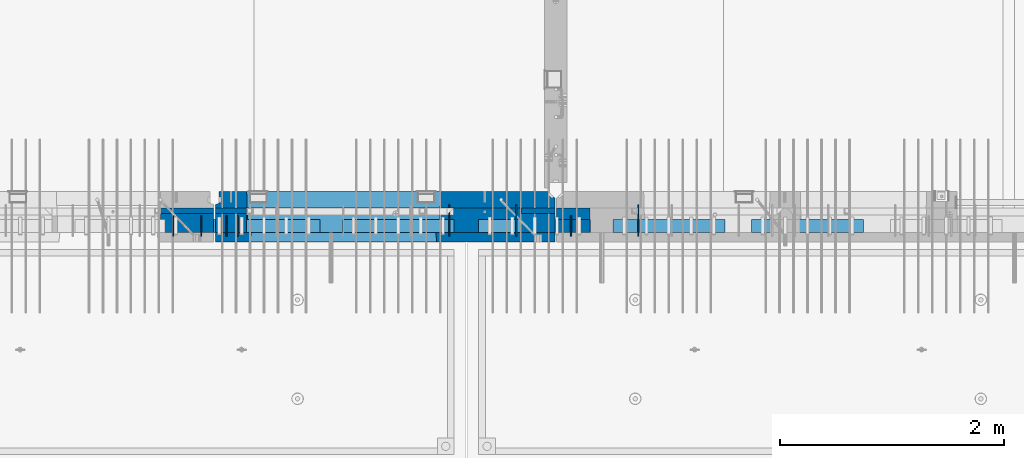
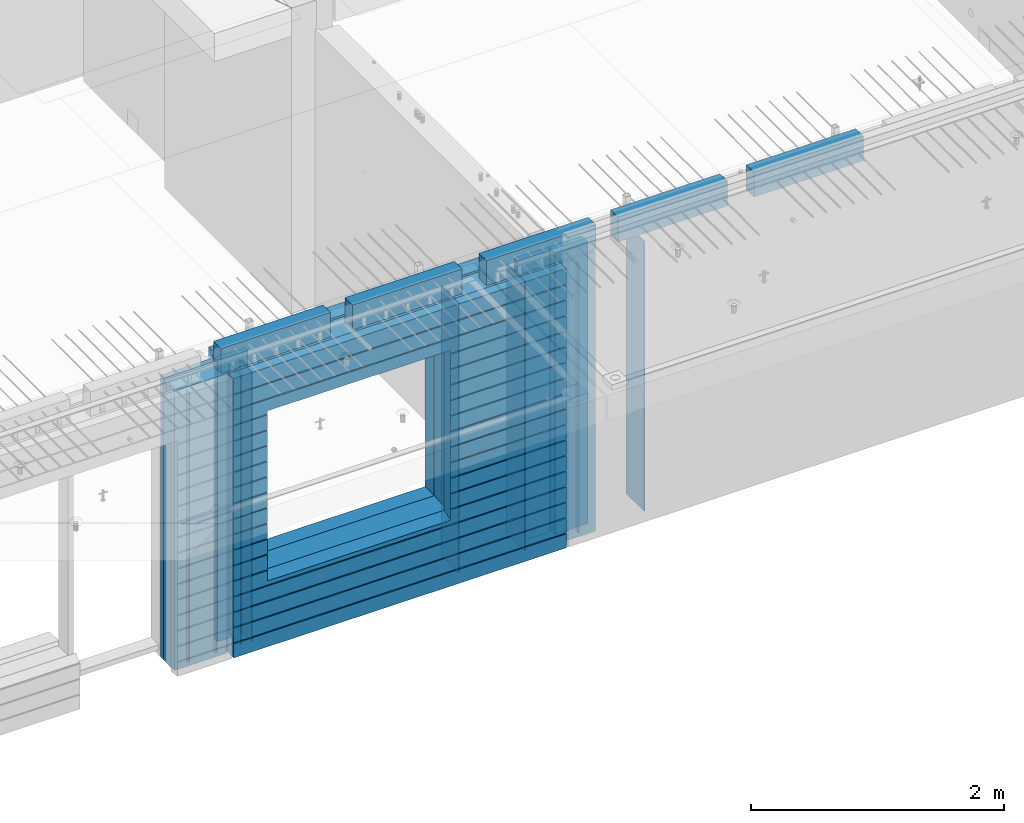
# One storey, part 224 of 341: 24 walls, 10 elements without a shape of their own.
"""IFC2X3 building model written with IfcOpenShell, lengths in millimetres."""

from ifc_helpers import new_model, si_unit, frame, origin_with_axes, place, context, subcontext, project, spatial, faceted_brep, material, type_object, element, aggregate, save


model = new_model("IFC2X3")

# Units and contexts
model_context = context("Model", 3, precision=1e-05, world=origin_with_axes())
body_context = subcontext(model_context, "Body", "Model", "MODEL_VIEW")
ifc_project = project(units=[si_unit("LENGTHUNIT", "METRE", prefix="MILLI"), si_unit("AREAUNIT", "SQUARE_METRE"), si_unit("VOLUMEUNIT", "CUBIC_METRE"), si_unit("MASSUNIT", "GRAM", prefix="KILO"), si_unit("TIMEUNIT", "SECOND"), si_unit("PLANEANGLEUNIT", "RADIAN"), si_unit("SOLIDANGLEUNIT", "STERADIAN"), si_unit("THERMODYNAMICTEMPERATUREUNIT", "DEGREE_CELSIUS"), si_unit("LUMINOUSINTENSITYUNIT", "LUMEN")], contexts=[model_context])

# Site, building, storey
site_placement = place(None, origin_with_axes())
site = spatial("IfcSite", under=ifc_project, at=site_placement, CompositionType="ELEMENT")
building_placement = place(site_placement, origin_with_axes())
building = spatial("IfcBuilding", under=site, at=building_placement, CompositionType="ELEMENT")
storey_placement = place(building_placement, origin_with_axes())
storey = spatial("IfcBuildingStorey", under=building, at=storey_placement, Name="5", CompositionType="ELEMENT", Elevation=0.0)

# Assembly, walls
assembly_1_placement = place(storey_placement, origin_with_axes())
assembly_1 = element("IfcElementAssembly", 1, at=assembly_1_placement, inside=storey, AssemblyPlace="NOTDEFINED", PredefinedType="REINFORCEMENT_UNIT")
ifc_material_1 = material(Name="Undefined")
wall_type_1 = type_object("IfcWallType", PredefinedType="NOTDEFINED")
wall_1_placement = place(assembly_1_placement, frame((25665.0, 7780.0, 95115.0), z_axis=(0.0, 0.0, 1.0), x_axis=(0.0, -1.0, 0.0)))
wall_1 = element("IfcWall", 2, at=wall_1_placement, type_object=wall_type_1, material=ifc_material_1, Name="(PD)", context=body_context, shape_type="Brep", body=[
    faceted_brep([(0.0, 5.0, -1300.0), (0.0, 5.0, 1300.0), (180.0, 5.0, 1300.0), (180.0, 5.0, -1300.0), (0.0, -5.0, 1300.0), (180.0, -5.0, 1300.0), (0.0, -5.0, -1300.0), (180.0, -5.0, -1300.0)], [[[0, 1, 2, 3]], [[1, 4, 5, 2]], [[4, 6, 7, 5]], [[6, 0, 3, 7]], [[5, 7, 3, 2]], [[6, 4, 1, 0]]]),
])
wall_2_placement = place(assembly_1_placement, frame((25765.0, 7780.0, 95115.0), z_axis=(0.0, 0.0, 1.0), x_axis=(0.0, -1.0, 0.0)))
wall_2 = element("IfcWall", 3, at=wall_2_placement, type_object=wall_type_1, material=ifc_material_1, Name="(PD)", context=body_context, shape_type="Brep", body=[
    faceted_brep([(0.0, 5.0, -1300.0), (0.0, 5.0, 1300.0), (180.0, 5.0, 1300.0), (180.0, 5.0, -1300.0), (0.0, -5.0, 1300.0), (180.0, -5.0, 1300.0), (0.0, -5.0, -1300.0), (180.0, -5.0, -1300.0)], [[[0, 1, 2, 3]], [[1, 4, 5, 2]], [[4, 6, 7, 5]], [[6, 0, 3, 7]], [[5, 7, 3, 2]], [[6, 4, 1, 0]]]),
])
wall_3_placement = place(assembly_1_placement, frame((28255.0, 7880.0, 95115.0), z_axis=(0.0, 0.0, 1.0), x_axis=(0.0, -1.0, 0.0)))
wall_3 = element("IfcWall", 4, at=wall_3_placement, type_object=wall_type_1, material=ifc_material_1, Name="(PD)", context=body_context, shape_type="Brep", body=[
    faceted_brep([(0.0, 5.0, -1300.0), (0.0, 5.0, 1300.0), (280.0, 5.0, 1300.0), (280.0, 5.0, -1300.0), (0.0, -5.0, 1300.0), (280.0, -5.0, 1300.0), (0.0, -5.0, -1300.0), (280.0, -5.0, -1300.0)], [[[0, 1, 2, 3]], [[1, 4, 5, 2]], [[4, 6, 7, 5]], [[6, 0, 3, 7]], [[5, 7, 3, 2]], [[6, 4, 1, 0]]]),
])

assembly_2_placement = place(storey_placement, origin_with_axes())
assembly_2 = element("IfcElementAssembly", 5, at=assembly_2_placement, inside=storey, AssemblyPlace="NOTDEFINED", PredefinedType="REINFORCEMENT_UNIT")
wall_4_placement = place(assembly_2_placement, frame((28745.0021834468, 7780.0, 95115.0), z_axis=(0.0, 0.0, 1.0), x_axis=(0.0, -1.0, 0.0)))
wall_4 = element("IfcWall", 6, at=wall_4_placement, type_object=wall_type_1, material=ifc_material_1, Name="(PD)", context=body_context, shape_type="Brep", body=[
    faceted_brep([(0.0, 5.0, -1300.0), (0.0, 5.0, 1300.0), (180.0, 5.0, 1300.0), (180.0, 5.0, -1300.0), (0.0, -5.0, 1300.0), (180.0, -5.0, 1300.0), (0.0, -5.0, -1300.0), (180.0, -5.0, -1300.0)], [[[0, 1, 2, 3]], [[1, 4, 5, 2]], [[4, 6, 7, 5]], [[6, 0, 3, 7]], [[5, 7, 3, 2]], [[6, 4, 1, 0]]]),
])
wall_5_placement = place(assembly_2_placement, frame((29345.0021834468, 7880.0, 95115.0), z_axis=(0.0, 0.0, 1.0), x_axis=(0.0, -1.0, 0.0)))
wall_5 = element("IfcWall", 7, at=wall_5_placement, type_object=wall_type_1, material=ifc_material_1, Name="(PD)", context=body_context, shape_type="Brep", body=[
    faceted_brep([(0.0, 5.0, -1300.0), (0.0, 5.0, 1300.0), (280.0, 5.0, 1300.0), (280.0, 5.0, -1300.0), (0.0, -5.0, 1300.0), (280.0, -5.0, 1300.0), (0.0, -5.0, -1300.0), (280.0, -5.0, -1300.0)], [[[0, 1, 2, 3]], [[1, 4, 5, 2]], [[4, 6, 7, 5]], [[6, 0, 3, 7]], [[5, 7, 3, 2]], [[6, 4, 1, 0]]]),
])

assembly_3_placement = place(storey_placement, origin_with_axes())
assembly_3 = element("IfcElementAssembly", 8, at=assembly_3_placement, inside=storey, AssemblyPlace="NOTDEFINED", PredefinedType="REINFORCEMENT_UNIT")
wall_6_placement = place(assembly_3_placement, frame((25190.0, 7780.0, 95115.0), z_axis=(0.0, 0.0, 1.0), x_axis=(0.0, -1.0, 0.0)))
wall_6 = element("IfcWall", 9, at=wall_6_placement, type_object=wall_type_1, material=ifc_material_1, Name="(PD)", context=body_context, shape_type="Brep", body=[
    faceted_brep([(0.0, 5.0, -1300.0), (0.0, 5.0, 1300.0), (180.0, 5.0, 1300.0), (180.0, 5.0, -1300.0), (0.0, -5.0, 1300.0), (180.0, -5.0, 1300.0), (0.0, -5.0, -1300.0), (180.0, -5.0, -1300.0)], [[[0, 1, 2, 3]], [[1, 4, 5, 2]], [[4, 6, 7, 5]], [[6, 0, 3, 7]], [[5, 7, 3, 2]], [[6, 4, 1, 0]]]),
])
wall_7_placement = place(assembly_3_placement, frame((25440.0, 7780.0, 95115.0), z_axis=(0.0, 0.0, 1.0), x_axis=(0.0, -1.0, 0.0)))
wall_7 = element("IfcWall", 10, at=wall_7_placement, type_object=wall_type_1, material=ifc_material_1, Name="(PD)", context=body_context, shape_type="Brep", body=[
    faceted_brep([(0.0, 5.0, -1300.0), (0.0, 5.0, 1300.0), (180.0, 5.0, 1300.0), (180.0, 5.0, -1300.0), (0.0, -5.0, 1300.0), (180.0, -5.0, 1300.0), (0.0, -5.0, -1300.0), (180.0, -5.0, -1300.0)], [[[0, 1, 2, 3]], [[1, 4, 5, 2]], [[4, 6, 7, 5]], [[6, 0, 3, 7]], [[5, 7, 3, 2]], [[6, 4, 1, 0]]]),
])

# Wall
wall_8_placement = place(assembly_1_placement, frame((27655.0, 7880.0, 95115.0), z_axis=(0.0, 0.0, 1.0), x_axis=(0.0, -1.0, 0.0)))
wall_8 = element("IfcWall", 11, at=wall_8_placement, type_object=wall_type_1, material=ifc_material_1, Name="(PD)", context=body_context, shape_type="Brep", body=[
    faceted_brep([(0.0, 5.0, -1300.0), (0.0, 5.0, 1300.0), (280.0, 5.0, 1300.0), (280.0, 5.0, -1300.0), (0.0, -5.0, 1300.0), (280.0, -5.0, 1300.0), (0.0, -5.0, -1300.0), (280.0, -5.0, -1300.0)], [[[0, 1, 2, 3]], [[1, 4, 5, 2]], [[4, 6, 7, 5]], [[6, 0, 3, 7]], [[5, 7, 3, 2]], [[6, 4, 1, 0]]]),
])

# Assemblies, walls
assembly_4_placement = place(storey_placement, origin_with_axes())
assembly_4 = element("IfcElementAssembly", 12, at=assembly_4_placement, inside=storey, AssemblyPlace="NOTDEFINED", PredefinedType="REINFORCEMENT_UNIT")
assembly_5_placement = place(assembly_4_placement, origin_with_axes())
assembly_5 = element("IfcElementAssembly", 13, at=assembly_5_placement, Name="Steel Assembly", AssemblyPlace="NOTDEFINED", PredefinedType="NOTDEFINED")
ifc_material_2 = material()
wall_type_2 = type_object("IfcWallType", PredefinedType="NOTDEFINED")
wall_9_placement = place(assembly_5_placement, frame((26699.9998568133, 7690.00021946163, 96590.0), z_axis=(0.0, 0.0, 1.0), x_axis=(1.0, 0.0, 0.0)))
wall_9 = element("IfcWall", 14, at=wall_9_placement, type_object=wall_type_2, material=ifc_material_2, context=body_context, shape_type="Brep", body=[
    faceted_brep([(0.0, 60.0, -120.0), (0.0, 60.0, 120.0), (1000.0, 60.0, 120.0), (1000.0, 60.0, -120.0), (0.0, -60.0, 120.0), (1000.0, -60.0, 120.0), (0.0, -60.0, -120.0), (1000.0, -60.0, -120.0)], [[[0, 1, 2, 3]], [[1, 4, 5, 2]], [[4, 6, 7, 5]], [[6, 0, 3, 7]], [[5, 7, 3, 2]], [[6, 4, 1, 0]]]),
])
aggregate(assembly_5, [wall_9])
assembly_6_placement = place(assembly_4_placement, origin_with_axes())
assembly_6 = element("IfcElementAssembly", 15, at=assembly_6_placement, Name="Steel Assembly", AssemblyPlace="NOTDEFINED", PredefinedType="NOTDEFINED")
aggregate(assembly_4, [assembly_6, assembly_5])
wall_10_placement = place(assembly_6_placement, frame((25499.9998568133, 7690.00021946163, 96590.0), z_axis=(0.0, 0.0, 1.0), x_axis=(1.0, 0.0, 0.0)))
wall_10 = element("IfcWall", 16, at=wall_10_placement, type_object=wall_type_2, material=ifc_material_2, context=body_context, shape_type="Brep", body=[
    faceted_brep([(0.0, 60.0, -120.0), (0.0, 60.0, 120.0), (1000.0, 60.0, 120.0), (1000.0, 60.0, -120.0), (0.0, -60.0, 120.0), (1000.0, -60.0, 120.0), (0.0, -60.0, -120.0), (1000.0, -60.0, -120.0)], [[[0, 1, 2, 3]], [[1, 4, 5, 2]], [[4, 6, 7, 5]], [[6, 0, 3, 7]], [[5, 7, 3, 2]], [[6, 4, 1, 0]]]),
])
aggregate(assembly_6, [wall_10])

assembly_7_placement = place(storey_placement, origin_with_axes())
assembly_7 = element("IfcElementAssembly", 17, at=assembly_7_placement, inside=storey, AssemblyPlace="NOTDEFINED", PredefinedType="REINFORCEMENT_UNIT")
assembly_8_placement = place(assembly_7_placement, origin_with_axes())
assembly_8 = element("IfcElementAssembly", 18, at=assembly_8_placement, Name="Steel Assembly", AssemblyPlace="NOTDEFINED", PredefinedType="NOTDEFINED")
wall_11_placement = place(assembly_8_placement, frame((30359.9998568133, 7690.00021946163, 96590.0), z_axis=(0.0, 0.0, 1.0), x_axis=(1.0, 0.0, 0.0)))
wall_11 = element("IfcWall", 19, at=wall_11_placement, type_object=wall_type_2, material=ifc_material_2, context=body_context, shape_type="Brep", body=[
    faceted_brep([(0.0, 60.0, -120.0), (0.0, 60.0, 120.0), (1000.0, 60.0, 120.0), (1000.0, 60.0, -120.0), (0.0, -60.0, 120.0), (1000.0, -60.0, 120.0), (0.0, -60.0, -120.0), (1000.0, -60.0, -120.0)], [[[0, 1, 2, 3]], [[1, 4, 5, 2]], [[4, 6, 7, 5]], [[6, 0, 3, 7]], [[5, 7, 3, 2]], [[6, 4, 1, 0]]]),
])
aggregate(assembly_8, [wall_11])
assembly_9_placement = place(assembly_7_placement, origin_with_axes())
assembly_9 = element("IfcElementAssembly", 20, at=assembly_9_placement, Name="Steel Assembly", AssemblyPlace="NOTDEFINED", PredefinedType="NOTDEFINED")
wall_12_placement = place(assembly_9_placement, frame((29119.9998568133, 7690.00021946163, 96590.0), z_axis=(0.0, 0.0, 1.0), x_axis=(1.0, 0.0, 0.0)))
wall_12 = element("IfcWall", 21, at=wall_12_placement, type_object=wall_type_2, material=ifc_material_2, context=body_context, shape_type="Brep", body=[
    faceted_brep([(0.0, 60.0, -120.0), (0.0, 60.0, 120.0), (1000.0, 60.0, 120.0), (1000.0, 60.0, -120.0), (0.0, -60.0, 120.0), (1000.0, -60.0, 120.0), (0.0, -60.0, -120.0), (1000.0, -60.0, -120.0)], [[[0, 1, 2, 3]], [[1, 4, 5, 2]], [[4, 6, 7, 5]], [[6, 0, 3, 7]], [[5, 7, 3, 2]], [[6, 4, 1, 0]]]),
])
aggregate(assembly_9, [wall_12])
assembly_10_placement = place(assembly_7_placement, origin_with_axes())
assembly_10 = element("IfcElementAssembly", 22, at=assembly_10_placement, Name="Steel Assembly", AssemblyPlace="NOTDEFINED", PredefinedType="NOTDEFINED")
aggregate(assembly_7, [assembly_10, assembly_9, assembly_8])
wall_13_placement = place(assembly_10_placement, frame((27919.9998568133, 7690.00021946163, 96590.0), z_axis=(0.0, 0.0, 1.0), x_axis=(1.0, 0.0, 0.0)))
wall_13 = element("IfcWall", 23, at=wall_13_placement, type_object=wall_type_2, material=ifc_material_2, context=body_context, shape_type="Brep", body=[
    faceted_brep([(0.0, 60.0, -120.0), (0.0, 60.0, 120.0), (1000.0, 60.0, 120.0), (1000.0, 60.0, -120.0), (0.0, -60.0, 120.0), (1000.0, -60.0, 120.0), (0.0, -60.0, -120.0), (1000.0, -60.0, -120.0)], [[[0, 1, 2, 3]], [[1, 4, 5, 2]], [[4, 6, 7, 5]], [[6, 0, 3, 7]], [[5, 7, 3, 2]], [[6, 4, 1, 0]]]),
])
aggregate(assembly_10, [wall_13])

# Wall
ifc_material_3 = material(Name="CONCRETE/C35/45")
wall_type_3 = type_object("IfcWallType", PredefinedType="NOTDEFINED")
wall_14_placement = place(assembly_1_placement, frame((28600.0, 7925.0, 95112.5), z_axis=(0.0, 0.0, 1.0), x_axis=(-1.0, 3.00000001838171e-08, 0.0)))
wall_14 = element("IfcWall", 24, at=wall_14_placement, type_object=wall_type_3, material=ifc_material_3, context=body_context, shape_type="Brep", body=[
    faceted_brep([(0.0, 75.0, 1357.5), (0.0, 75.0, -1357.5), (0.0, -15.0, -1357.5), (0.0, -15.0, 1357.5), (60.0, -75.0, -1357.5), (3035.00000000003, 75.0, -1357.5), (3035.00000000003, 45.0, -1357.5), (3002.5, 32.0, -1357.5), (3002.5, -75.0, -1357.5), (60.0, -75.0, 1357.5), (3035.00000000003, 45.0, 1357.5), (3035.00000000003, 75.0, 1357.5), (3002.5, -75.0, 1357.5), (3002.5, 32.0, 1357.5), (2755.00051719707, -75.0, -682.5), (1025.00051719707, -75.0, -682.5), (1025.00051719707, -75.0, 952.5), (2755.00051719707, -75.0, 952.5), (2750.94646314301, 75.0, -678.445945945947), (1029.05457125112, 75.0, -678.445945945947), (1029.05457125112, 75.0, 948.445945945947), (2750.94646314301, 75.0, 948.445945945947)], [[[0, 1, 2, 3]], [[4, 2, 1, 5, 6, 7, 8]], [[3, 2, 4, 9]], [[10, 11, 0, 3, 9, 12, 13]], [[5, 11, 10, 6]], [[13, 7, 6, 10]], [[12, 8, 7, 13]], [[9, 4, 8, 12], [14, 15, 16, 17]], [[14, 18, 19, 15]], [[15, 19, 20, 16]], [[1, 0, 11, 5], [18, 21, 20, 19]], [[16, 20, 21, 17]], [[18, 14, 17, 21]]]),
])

wall_type_4 = type_object("IfcWallType", PredefinedType="NOTDEFINED")
wall_15_placement = place(assembly_2_placement, frame((28915.0000381475, 7800.0, 95112.5), z_axis=(0.0, 0.0, 1.0), x_axis=(-1.0, 3.00000001838171e-08, 0.0)))
wall_15 = element("IfcWall", 25, at=wall_15_placement, type_object=wall_type_4, material=ifc_material_3, context=body_context, shape_type="Brep", body=[
    faceted_brep([(0.0, 50.0, -1357.5), (0.0, 50.0, 1357.5), (300.001908754726, 50.0, 1357.5), (300.001908754726, 50.0, -1357.5), (0.0, -50.0, 1357.5), (300.001908754726, -50.0, 1357.5), (0.0, -50.0, -1357.5), (300.001908754726, -50.0, -1357.5)], [[[0, 1, 2, 3]], [[1, 4, 5, 2]], [[4, 6, 7, 5]], [[6, 0, 3, 7]], [[5, 7, 3, 2]], [[6, 4, 1, 0]]]),
])

ifc_material_4 = material(Name="SPU")
wall_type_5 = type_object("IfcWallType", PredefinedType="NOTDEFINED")
wall_16_placement = place(assembly_2_placement, frame((28915.0000381475, 7690.0, 95102.5), z_axis=(0.0, 0.0, 1.0), x_axis=(-1.0, 3.00000001838171e-08, 0.0)))
wall_16 = element("IfcWall", 26, at=wall_16_placement, type_object=wall_type_5, material=ifc_material_4, context=body_context, shape_type="Brep", body=[
    faceted_brep([(0.0, 60.0, -1347.5), (0.0, 60.0, 1347.5), (300.001908754726, 60.0, 1347.5), (300.001908754726, 60.0, -1347.5), (0.0, -60.0, 1347.5), (300.001908754726, -60.0, 1347.5), (0.0, -60.0, -1347.5), (300.001908754726, -60.0, -1347.5)], [[[0, 1, 2, 3]], [[1, 4, 5, 2]], [[4, 6, 7, 5]], [[6, 0, 3, 7]], [[5, 7, 3, 2]], [[6, 4, 1, 0]]]),
])

aggregate(assembly_2, [wall_16, wall_15, wall_4, wall_5])

wall_type_6 = type_object("IfcWallType", PredefinedType="NOTDEFINED")
wall_17_placement = place(assembly_1_placement, frame((28600.0000381475, 7825.0, 95112.5), z_axis=(0.0, 0.0, 1.0), x_axis=(-1.0, 3.00000001838171e-08, 0.0)))
wall_17 = element("IfcWall", 27, at=wall_17_placement, type_object=wall_type_6, material=ifc_material_3, context=body_context, shape_type="Brep", body=[
    faceted_brep([(0.0, 25.0, -1357.5), (0.0, 25.0, 1357.5), (300.001908754726, 25.0, 1357.5), (300.001908754726, 25.0, -1357.5), (0.0, -25.0, 1357.5), (300.001908754726, -25.0, 1357.5), (0.0, -25.0, -1357.5), (300.001908754726, -25.0, -1357.5)], [[[0, 1, 2, 3]], [[1, 4, 5, 2]], [[4, 6, 7, 5]], [[6, 0, 3, 7]], [[5, 7, 3, 2]], [[6, 4, 1, 0]]]),
])

wall_18_placement = place(assembly_3_placement, frame((25550.0000381475, 7825.00011629906, 95112.5), z_axis=(0.0, 0.0, 1.0), x_axis=(-1.0, 3.00000001838171e-08, 0.0)))
wall_18 = element("IfcWall", 28, at=wall_18_placement, type_object=wall_type_6, material=ifc_material_3, context=body_context, shape_type="Brep", body=[
    faceted_brep([(0.0, 25.0, -1357.5), (0.0, 25.0, 1357.5), (475.001908754726, 25.0, 1357.5), (475.001908754726, 25.0, -1357.5), (0.0, -25.0, 1357.5), (475.001908754726, -25.0, 1357.5), (0.0, -25.0, -1357.5), (475.001908754726, -25.0, -1357.5)], [[[0, 1, 2, 3]], [[1, 4, 5, 2]], [[4, 6, 7, 5]], [[6, 0, 3, 7]], [[5, 7, 3, 2]], [[6, 4, 1, 0]]]),
])

wall_19_placement = place(assembly_1_placement, frame((25845.0000381475, 7825.0, 95112.5), z_axis=(0.0, 0.0, 1.0), x_axis=(-1.0, 3.00000001838171e-08, 0.0)))
wall_19 = element("IfcWall", 29, at=wall_19_placement, type_object=wall_type_6, material=ifc_material_3, context=body_context, shape_type="Brep", body=[
    faceted_brep([(0.0, 25.0, -1357.5), (0.0, 25.0, 1357.5), (280.001908754726, 25.0, 1357.5), (280.001908754726, 25.0, -1357.5), (0.0, -25.0, 1357.5), (280.001908754726, -25.0, 1357.5), (0.0, -25.0, -1357.5), (280.001908754726, -25.0, -1357.5)], [[[0, 1, 2, 3]], [[1, 4, 5, 2]], [[4, 6, 7, 5]], [[6, 0, 3, 7]], [[5, 7, 3, 2]], [[6, 4, 1, 0]]]),
])

wall_type_7 = type_object("IfcWallType", PredefinedType="NOTDEFINED")
wall_20_placement = place(assembly_3_placement, frame((25550.0000381475, 7715.00011629906, 95102.5), z_axis=(0.0, 0.0, 1.0), x_axis=(-1.0, 3.00000001838171e-08, 0.0)))
wall_20 = element("IfcWall", 30, at=wall_20_placement, type_object=wall_type_7, material=ifc_material_4, context=body_context, shape_type="Brep", body=[
    faceted_brep([(0.0, 85.0, -1347.5), (0.0, 85.0, 1347.5), (475.001908754726, 85.0, 1347.5), (475.001908754726, 85.0, -1347.5), (0.0, -85.0, 1347.5), (475.001908754726, -85.0, 1347.5), (0.0, -85.0, -1347.5), (475.001908754726, -85.0, -1347.5)], [[[0, 1, 2, 3]], [[1, 4, 5, 2]], [[4, 6, 7, 5]], [[6, 0, 3, 7]], [[5, 7, 3, 2]], [[6, 4, 1, 0]]]),
])

aggregate(assembly_3, [wall_20, wall_18, wall_6, wall_7])

wall_21_placement = place(assembly_1_placement, frame((28600.0000381475, 7715.0, 95102.5), z_axis=(0.0, 0.0, 1.0), x_axis=(-1.0, 3.00000001838171e-08, 0.0)))
wall_21 = element("IfcWall", 31, at=wall_21_placement, type_object=wall_type_7, material=ifc_material_4, context=body_context, shape_type="Brep", body=[
    faceted_brep([(0.0, 85.0, -1347.5), (0.0, 85.0, 1347.5), (300.001908754726, 85.0, 1347.5), (300.001908754726, 85.0, -1347.5), (0.0, -85.0, 1347.5), (300.001908754726, -85.0, 1347.5), (0.0, -85.0, -1347.5), (300.001908754726, -85.0, -1347.5)], [[[0, 1, 2, 3]], [[1, 4, 5, 2]], [[4, 6, 7, 5]], [[6, 0, 3, 7]], [[5, 7, 3, 2]], [[6, 4, 1, 0]]]),
])

wall_22_placement = place(assembly_1_placement, frame((25845.0000381475, 7715.0, 95102.5), z_axis=(0.0, 0.0, 1.0), x_axis=(-1.0, 3.00000001838171e-08, 0.0)))
wall_22 = element("IfcWall", 32, at=wall_22_placement, type_object=wall_type_7, material=ifc_material_4, context=body_context, shape_type="Brep", body=[
    faceted_brep([(0.0, 85.0, -1347.5), (0.0, 85.0, 1347.5), (280.001908754726, 85.0, 1347.5), (280.001908754726, 85.0, -1347.5), (0.0, -85.0, 1347.5), (280.001908754726, -85.0, 1347.5), (0.0, -85.0, -1347.5), (280.001908754726, -85.0, -1347.5)], [[[0, 1, 2, 3]], [[1, 4, 5, 2]], [[4, 6, 7, 5]], [[6, 0, 3, 7]], [[5, 7, 3, 2]], [[6, 4, 1, 0]]]),
])

ifc_material_5 = material(Name="CONCRETE/C30/37")
wall_type_8 = type_object("IfcWallType", PredefinedType="NOTDEFINED")
wall_23_placement = place(assembly_1_placement, frame((28600.0, 7587.5, 95102.5), z_axis=(0.0, 0.0, 1.0), x_axis=(-1.0, 3.00000001838171e-08, 0.0)))
wall_23 = element("IfcWall", 33, at=wall_23_placement, type_object=wall_type_8, material=ifc_material_5, context=body_context, shape_type="Brep", body=[
    faceted_brep([(3.63797880709171e-12, 32.4999991119639, 1050.00000040043), (3035.0, 32.4999991119785, 1050.00000040044), (3035.0, 32.4999992499725, 1039.99999999921), (3.63797880709171e-12, 32.4999992499725, 1039.99999999921), (0.0, 42.5, 1051.99999988925), (3035.0, 42.5, 1051.99999988925), (0.0, 42.5, 1187.99999994476), (3035.0, 42.5, 1187.99999994476), (-3.63797880709171e-12, 32.499999249967, 1189.99999999923), (3035.0, 32.4999992499634, 1189.99999999921), (-3.63797880709171e-12, 32.4999991119576, 1200.00000040043), (3035.0, 32.4999991119703, 1200.00000040044), (0.0, 42.5, 1201.99999988925), (3035.0, 42.5, 1201.99999988925), (0.0, 42.5, 1347.5), (3035.0, 42.5, 1347.5), (0.0, -42.5, 1347.5), (3035.0, -42.5, 1347.5), (0.0, -42.5, -1347.5), (0.0, 42.5, -1347.5), (3035.0, 42.5, -1347.5), (3035.0, -42.5, -1347.5), (0.0, 42.5, -1212.00000005524), (3035.0, 42.5, -1212.00000005524), (0.0, 32.4999992501671, -1210.00000000079), (3035.0, 32.4999992501644, -1210.0000000008), (0.0, 32.4999991121604, -1199.99999959957), (3035.0, 32.4999991121604, -1199.99999959957), (0.0, 42.5, -1198.00000011075), (3035.0, 42.5, -1198.00000011075), (0.0, 42.5, -1062.00000005522), (3035.0, 42.5, -1062.00000005522), (0.0, 32.4999992506973, -1060.00000000076), (3035.0, 32.4999992506928, -1060.00000000079), (0.0, 32.4999991126861, -1049.99999959956), (3035.0, 32.4999991126924, -1049.99999959956), (0.0, 42.5, -1048.00000011074), (3035.0, 42.5, -1048.00000011074), (0.0, 42.5, -912.000000055254), (3035.0, 42.5, -912.000000055254), (0.0, 32.4999992512376, -910.000000000786), (3035.0, 32.4999992512339, -910.000000000815), (0.0, 32.499999113239, -899.99999959959), (3035.0, 32.4999991132327, -899.99999959959), (0.0, 42.5, -898.000000110769), (3035.0, 42.5, -898.000000110769), (0.0, 42.5, -762.000000055225), (3035.0, 42.5, -762.000000055225), (0.0, 32.4999992517696, -760.000000000757), (3035.0, 32.499999251766, -760.000000000786), (0.0, 32.4999991137702, -749.99999959956), (3035.0, 32.4999991137656, -749.99999959956), (0.0, 42.5, -748.00000011074), (3035.0, 42.5, -748.00000011074), (3035.0, 42.5, 901.999999889245), (3035.0, 32.4999991119894, 900.00000040044), (2723.82404650436, 32.4999991119894, 900.00000040044), (2725.00051719707, 42.5, 901.999999889245), (3035.0, 32.4999992499834, 889.999999999214), (2723.82404652059, 32.4999992499834, 889.999999999214), (3035.0, 42.5, 887.999999944761), (2725.00051719707, 42.5, 887.999999944761), (3035.0, 42.5, 751.999999889245), (2725.00051719707, 42.5, 751.999999889245), (3035.0, 32.4999991119967, 750.000000400425), (2723.82404650436, 32.4999991119967, 750.000000400425), (3035.0, 32.4999992499961, 739.9999999992), (2723.82404652059, 32.4999992499961, 739.9999999992), (3035.0, 42.5, 737.999999944761), (2725.00051719707, 42.5, 737.999999944761), (3035.0, 42.5, 601.99999988926), (2725.00051719707, 42.5, 601.99999988926), (3035.0, 32.4999991120212, 600.000000400454), (2723.82404650436, 32.4999991120212, 600.000000400454), (3035.0, 32.4999992500161, 589.999999999229), (2723.8240465206, 32.4999992500161, 589.999999999229), (3035.0, 42.5, 587.999999944775), (2725.00051719707, 42.5, 587.999999944775), (3035.0, 42.5, 451.999999889231), (2725.00051719707, 42.5, 451.999999889231), (3035.0, 32.4999991120285, 450.000000400425), (2723.82404650436, 32.4999991120285, 450.000000400425), (3035.0, 32.4999992500234, 439.9999999992), (2723.8240465206, 32.4999992500234, 439.9999999992), (3035.0, 42.5, 437.999999944746), (2725.00051719707, 42.5, 437.999999944746), (3035.0, 42.5, 301.999999889245), (2725.00051719707, 42.5, 301.999999889245), (3035.0, 32.4999991120458, 300.00000040044), (2723.82404650437, 32.4999991120458, 300.00000040044), (3035.0, 32.4999992500389, 289.999999999214), (2723.8240465206, 32.4999992500389, 289.999999999214), (3035.0, 42.5, 287.999999944761), (2725.00051719707, 42.5, 287.999999944761), (3035.0, 42.5, 151.99999988926), (2725.00051719707, 42.5, 151.99999988926), (3035.0, 32.4999991120585, 150.000000400454), (2723.82404650437, 32.4999991120585, 150.000000400454), (3035.0, 32.4999992500534, 139.999999999229), (2723.8240465206, 32.4999992500534, 139.999999999229), (3035.0, 42.5, 137.999999944775), (2725.00051719707, 42.5, 137.999999944775), (3035.0, 42.5, 1.99999988924537), (2725.00051719707, 42.5, 1.99999988924537), (3035.0, 32.4999992522926, -610.0000000008), (3035.0, 42.5, -612.000000055239), (2725.00051719707, 42.5, -612.000000055239), (2723.82404652087, 32.4999992522926, -610.0000000008), (3035.0, 32.4999991142904, -599.999999599575), (2723.82404650463, 32.4999991142904, -599.999999599575), (3035.0, 42.5, -598.000000110755), (2725.00051719707, 42.5, -598.000000110755), (3035.0, 42.5, -462.000000055239), (2725.00051719707, 42.5, -462.000000055239), (3035.0, 32.4999992528319, -460.0000000008), (2723.82404652093, 32.4999992528319, -460.0000000008), (3035.0, 32.4999991148297, -449.999999599575), (2723.82404650469, 32.4999991148297, -449.999999599575), (3035.0, 42.5, -448.000000110755), (2725.00051719707, 42.5, -448.000000110755), (3035.0, 42.5, -312.000000055254), (2725.00051719707, 42.5, -312.000000055254), (3035.0, 32.4999992533585, -310.000000000815), (2723.82404652099, 32.4999992533585, -310.000000000815), (3035.0, 32.4999991153563, -299.99999959959), (2723.82404650475, 32.4999991153563, -299.99999959959), (3035.0, 42.5, -298.000000110769), (2725.00051719707, 42.5, -298.000000110769), (3035.0, 42.5, -162.000000055239), (2725.00051719707, 42.499999923677, -162.000000055239), (3035.0, 32.4999992538951, -160.0000000008), (2723.82404652105, 32.4999992538951, -160.0000000008), (3035.0, 32.4999991158938, -149.999999599575), (2723.82404650482, 32.4999991158938, -149.999999599575), (3035.0, 42.5, -148.000000110755), (2725.00051719707, 42.4999999210722, -148.000000110755), (3035.0, 42.5, -12.0000000552391), (2725.00051719707, 42.5, -12.0000000552391), (3035.0, 32.4999992538906, -10.0000000008004), (2723.82404652105, 32.4999992538906, -10.0000000008004), (3035.0, 32.4999991158902, 4.00425051338971e-07), (2723.82404650482, 32.4999991158902, 4.00425051338971e-07), (3035.0, 42.5, 1037.99999994476), (0.0, 42.5, 1037.99999994476), (3.63797880709171e-12, 32.4999992499852, 889.999999999229), (3.63797880709171e-12, 32.4999991119857, 900.000000400425), (1056.17698788978, 32.4999991119894, 900.00000040044), (1056.17698787354, 32.4999992499834, 889.999999999214), (0.0, 42.5, 887.999999944761), (1055.00051719707, 42.5, 887.999999944761), (0.0, 42.5, 751.999999889245), (1055.00051719707, 42.5, 751.999999889245), (0.0, 32.4999991120039, 750.00000040044), (1056.17698788978, 32.4999991119967, 750.000000400425), (0.0, 32.4999992499997, 739.999999999229), (1056.17698787354, 32.4999992499961, 739.9999999992), (0.0, 42.5, 737.999999944761), (1055.00051719707, 42.5, 737.999999944761), (0.0, 42.5, 601.99999988926), (1055.00051719707, 42.5, 601.99999988926), (0.0, 32.4999991120094, 600.00000040044), (1056.17698788977, 32.4999991120212, 600.000000400454), (0.0, 32.499999250017, 589.999999999229), (1056.17698787354, 32.4999992500161, 589.999999999229), (0.0, 42.5, 587.999999944775), (1055.00051719707, 42.5, 587.999999944775), (0.0, 42.5, 451.999999889231), (1055.00051719707, 42.5, 451.999999889231), (0.0, 32.4999991120258, 450.000000400411), (1056.17698788977, 32.4999991120285, 450.000000400425), (0.0, 32.4999992500289, 439.999999999214), (1056.17698787354, 32.4999992500234, 439.9999999992), (0.0, 42.5, 437.999999944746), (1055.00051719707, 42.5, 437.999999944746), (0.0, 42.5, 301.999999889245), (1055.00051719707, 42.5, 301.999999889245), (-3.63797880709171e-12, 32.4999991120458, 300.00000040044), (1056.17698788977, 32.4999991120458, 300.00000040044), (-3.63797880709171e-12, 32.4999992500416, 289.999999999229), (1056.17698787353, 32.4999992500389, 289.999999999214), (0.0, 42.5, 287.999999944761), (1055.00051719707, 42.5, 287.999999944761), (0.0, 42.5, 151.99999988926), (1055.00051719707, 42.5, 151.99999988926), (0.0, 32.4999991120549, 150.00000040044), (1056.17698788977, 32.4999991120585, 150.000000400454), (0.0, 32.4999992500552, 139.999999999229), (1056.17698787353, 32.4999992500534, 139.999999999229), (0.0, 42.5, 137.999999944775), (1055.00051719707, 42.5, 137.999999944775), (0.0, 42.5, 1.99999988924537), (1055.00051719707, 42.5, 1.99999988924537), (0.0, 42.5, -12.0000000552391), (0.0, 42.5, -148.000000110755), (0.0, 32.4999991158993, -149.99999959956), (0.0, 32.4999992538978, -160.000000000757), (0.0, 42.5, -162.000000055239), (0.0, 42.5, -298.000000110769), (0.0, 32.4999991153618, -299.99999959959), (0.0, 32.4999992533649, -310.000000000786), (0.0, 42.5, -312.000000055254), (0.0, 42.5, -448.000000110755), (0.0, 32.4999991148252, -449.999999599575), (0.0, 32.4999992528365, -460.000000000771), (0.0, 42.5, -462.000000055239), (0.0, 42.5, -598.000000110755), (0.0, 32.4999991143004, -599.99999959956), (0.0, 32.4999992522971, -610.000000000771), (0.0, 42.5, -612.000000055239), (0.0, 42.5, 901.999999889245), (0.0, 32.4999991158911, 4.00425051338971e-07), (0.0, 32.4999992538942, -10.0000000007858), (1056.17698788932, 32.4999991158902, 4.00425051338971e-07), (1056.17698787308, 32.4999992538906, -10.0000000008004), (1055.00051719707, 42.5, -12.0000000552391), (1055.00051719707, 42.4999994958771, -148.000000110755), (1056.17698788932, 32.4999991158938, -149.999999599575), (1056.17698787308, 32.4999992538951, -160.0000000008), (1055.00051719707, 42.499999512519, -162.000000055239), (1055.00051719707, 42.5, -298.000000110769), (1056.17698788938, 32.4999991153563, -299.99999959959), (1056.17698787315, 32.4999992533585, -310.000000000815), (1055.00051719707, 42.5, -312.000000055254), (1055.00051719707, 42.5, -448.000000110755), (1056.17698788944, 32.4999991148297, -449.999999599575), (1056.17698787321, 32.4999992528319, -460.0000000008), (1055.00051719707, 42.5, -462.000000055239), (1055.00051719707, 42.5, -598.000000110755), (1056.1769878895, 32.4999991142904, -599.999999599575), (1056.17698787327, 32.4999992522926, -610.0000000008), (1055.00051719707, 42.5, -612.000000055239), (2725.00051719707, 42.5, -712.5), (1055.00051719707, 42.5, -712.5), (2715.00051719707, -42.5, 927.5), (2715.00051719707, -42.5, 932.5), (2725.00051719707, 42.5, 927.5), (2715.00051719707, -42.5, -662.5), (1065.00051719707, -42.5, -662.5), (1065.00051719707, -42.5, 927.5), (1065.00051719707, -42.5, 932.5), (1065.00051719707, 42.5, 927.5), (2715.00051719707, 42.5, 927.5), (1055.00051719707, 42.5, 927.5), (1055.00051719707, 42.5, 901.999999889245)], [[[0, 1, 2, 3]], [[4, 5, 1, 0]], [[5, 4, 6, 7]], [[8, 9, 7, 6]], [[10, 11, 9, 8]], [[12, 13, 11, 10]], [[14, 15, 13, 12]], [[14, 16, 17, 15]], [[18, 19, 20, 21]], [[20, 19, 22, 23]], [[24, 25, 23, 22]], [[26, 27, 25, 24]], [[28, 29, 27, 26]], [[29, 28, 30, 31]], [[32, 33, 31, 30]], [[34, 35, 33, 32]], [[36, 37, 35, 34]], [[37, 36, 38, 39]], [[40, 41, 39, 38]], [[42, 43, 41, 40]], [[44, 45, 43, 42]], [[45, 44, 46, 47]], [[48, 49, 47, 46]], [[50, 51, 49, 48]], [[52, 53, 51, 50]], [[54, 55, 56, 57]], [[55, 58, 59, 56]], [[58, 60, 61, 59]], [[60, 62, 63, 61]], [[62, 64, 65, 63]], [[64, 66, 67, 65]], [[66, 68, 69, 67]], [[68, 70, 71, 69]], [[70, 72, 73, 71]], [[72, 74, 75, 73]], [[74, 76, 77, 75]], [[76, 78, 79, 77]], [[78, 80, 81, 79]], [[80, 82, 83, 81]], [[82, 84, 85, 83]], [[84, 86, 87, 85]], [[86, 88, 89, 87]], [[88, 90, 91, 89]], [[90, 92, 93, 91]], [[92, 94, 95, 93]], [[94, 96, 97, 95]], [[96, 98, 99, 97]], [[98, 100, 101, 99]], [[100, 102, 103, 101]], [[104, 105, 106, 107]], [[108, 104, 107, 109]], [[110, 108, 109, 111]], [[112, 110, 111, 113]], [[114, 112, 113, 115]], [[116, 114, 115, 117]], [[118, 116, 117, 119]], [[120, 118, 119, 121]], [[122, 120, 121, 123]], [[124, 122, 123, 125]], [[126, 124, 125, 127]], [[128, 126, 127, 129]], [[130, 128, 129, 131]], [[132, 130, 131, 133]], [[134, 132, 133, 135]], [[136, 134, 135, 137]], [[138, 136, 137, 139]], [[140, 138, 139, 141]], [[102, 140, 141, 103]], [[100, 98, 96, 94, 92, 90, 88, 86, 84, 82, 80, 78, 76, 74, 72, 70, 68, 66, 64, 62, 60, 58, 55, 54, 142, 2, 1, 5, 7, 9, 11, 13, 15, 17, 21, 20, 23, 25, 27, 29, 31, 33, 35, 37, 39, 41, 43, 45, 47, 49, 51, 53, 105, 104, 108, 110, 112, 114, 116, 118, 120, 122, 124, 126, 128, 130, 132, 134, 136, 138, 140, 102]], [[3, 2, 142, 143]], [[144, 145, 146, 147]], [[148, 144, 147, 149]], [[150, 148, 149, 151]], [[152, 150, 151, 153]], [[154, 152, 153, 155]], [[156, 154, 155, 157]], [[158, 156, 157, 159]], [[160, 158, 159, 161]], [[162, 160, 161, 163]], [[164, 162, 163, 165]], [[166, 164, 165, 167]], [[168, 166, 167, 169]], [[170, 168, 169, 171]], [[172, 170, 171, 173]], [[174, 172, 173, 175]], [[176, 174, 175, 177]], [[178, 176, 177, 179]], [[180, 178, 179, 181]], [[182, 180, 181, 183]], [[184, 182, 183, 185]], [[186, 184, 185, 187]], [[188, 186, 187, 189]], [[190, 188, 189, 191]], [[192, 193, 194, 195, 196, 197, 198, 199, 200, 201, 202, 203, 204, 205, 206, 207, 208, 52, 50, 48, 46, 44, 42, 40, 38, 36, 34, 32, 30, 28, 26, 24, 22, 19, 18, 16, 14, 12, 10, 8, 6, 4, 0, 3, 143, 209, 145, 144, 148, 150, 152, 154, 156, 158, 160, 162, 164, 166, 168, 170, 172, 174, 176, 178, 180, 182, 184, 186, 188, 190, 210, 211]], [[211, 210, 212, 213]], [[192, 211, 213, 214]], [[193, 192, 214, 215]], [[194, 193, 215, 216]], [[195, 194, 216, 217]], [[196, 195, 217, 218]], [[197, 196, 218, 219]], [[198, 197, 219, 220]], [[199, 198, 220, 221]], [[200, 199, 221, 222]], [[201, 200, 222, 223]], [[202, 201, 223, 224]], [[203, 202, 224, 225]], [[204, 203, 225, 226]], [[205, 204, 226, 227]], [[206, 205, 227, 228]], [[207, 206, 228, 229]], [[208, 207, 229, 230]], [[231, 106, 105, 53, 52, 208, 230, 232]], [[233, 234, 235, 57, 56, 59, 61, 63, 65, 67, 69, 71, 73, 75, 77, 79, 81, 83, 85, 87, 89, 91, 93, 95, 97, 99, 101, 103, 141, 139, 137, 135, 133, 131, 129, 127, 125, 123, 121, 119, 117, 115, 113, 111, 109, 107, 106, 231, 236]], [[232, 237, 236, 231]], [[16, 18, 21, 17], [233, 236, 237, 238, 239, 234]], [[240, 241, 235, 234, 239, 242]], [[209, 143, 142, 54, 57, 235, 241, 240, 242, 243]], [[145, 209, 243, 146]], [[242, 239, 238, 237, 232, 230, 229, 228, 227, 226, 225, 224, 223, 222, 221, 220, 219, 218, 217, 216, 215, 214, 213, 212, 191, 189, 187, 185, 183, 181, 179, 177, 175, 173, 171, 169, 167, 165, 163, 161, 159, 157, 155, 153, 151, 149, 147, 146, 243]], [[210, 190, 191, 212]]]),
])

ifc_material_6 = material(Name="COS5gt")
wall_type_9 = type_object("IfcWallType", PredefinedType="NOTDEFINED")
wall_24_placement = place(assembly_1_placement, frame((28600.0, 7740.0, 95102.5), z_axis=(0.0, 0.0, 1.0), x_axis=(-1.0, 3.00000001838171e-08, 0.0)))
wall_24 = element("IfcWall", 34, at=wall_24_placement, type_object=wall_type_9, material=ifc_material_6, context=body_context, shape_type="Brep", body=[
    faceted_brep([(2755.0, 90.0, -1347.5), (2755.0, -110.0, -1347.5), (300.001870607201, -110.0, -1347.5), (300.001870607201, 90.0, -1347.5), (2755.0, 90.0, -1297.5), (300.001870607201, 90.0, -1297.5), (2755.0, 110.0, -1297.5), (300.001870607201, 110.0, -1297.5), (2755.0, 110.0, 1347.5), (2755.0, -110.0, 1347.5), (2750.94646314301, -110.0, -668.445945945947), (2745.00051719707, 110.0, -662.5), (2715.00051719707, 110.0, -662.5), (1065.00051719707, 110.0, -662.5), (1035.00051719707, 110.0, -662.5), (1029.05457125112, -110.0, -668.445945945947), (300.001870607201, -110.0, 1347.5), (1029.05457125112, -110.0, 958.445945945947), (2750.94646314301, -110.0, 958.445945945947), (2745.00051719707, 110.0, -657.5), (2745.00051719707, 110.0, 952.5), (1035.00051719707, 110.0, 952.5), (1035.00051719707, 110.0, -657.5), (300.001870607201, 110.0, 1347.5)], [[[0, 1, 2, 3]], [[4, 0, 3, 5]], [[6, 4, 5, 7]], [[8, 9, 1, 0, 4, 6]], [[10, 11, 12, 13, 14, 15]], [[1, 9, 16, 2], [10, 15, 17, 18]], [[19, 11, 10, 18, 20]], [[17, 21, 20, 18]], [[15, 14, 22, 21, 17]], [[8, 6, 7, 23], [14, 13, 12, 11, 19, 20, 21, 22]], [[9, 8, 23, 16]], [[7, 5, 3, 2, 16, 23]]]),
])

aggregate(assembly_1, [wall_21, wall_17, wall_22, wall_1, wall_2, wall_3, wall_19, wall_8, wall_23, wall_24, wall_14])

save(model, "model.ifc")
